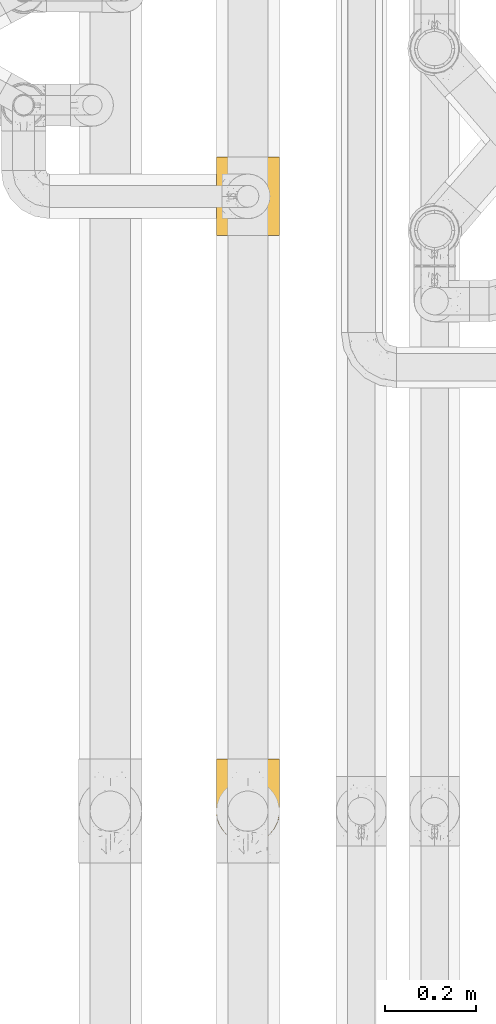
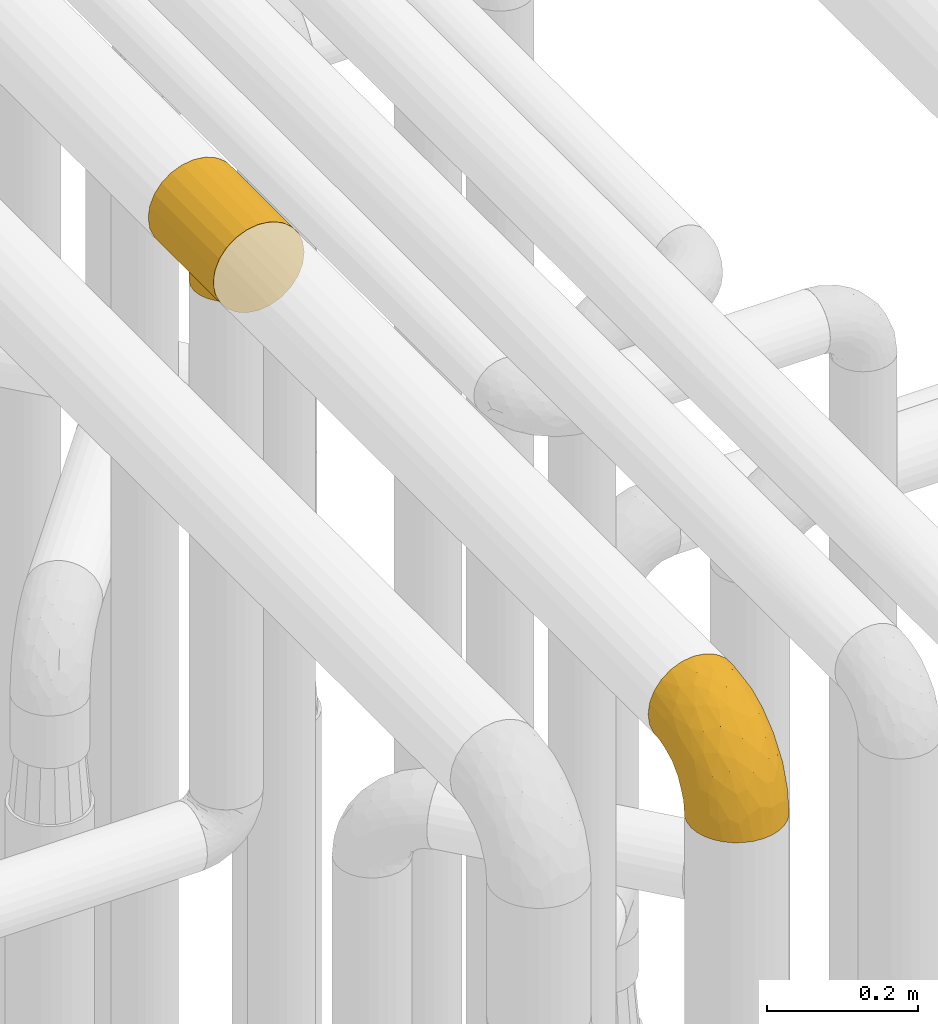
# One storey, part 191 of 827: 2 coverings.
"""IFC2X3 building model written with IfcOpenShell, lengths in millimetres."""

from ifc_helpers import new_model, entity, si_unit, converted_unit, derived_unit, direction, frame, origin, place, context, subcontext, project, spatial, faceted_brep, element, save


model = new_model("IFC2X3")

# Units and contexts
model_context = context("Model", 3, precision=0.01, world=origin(), true_north=direction((6.12303176911189e-17, 1.0)))
body_context = subcontext(model_context, "Body", "Model", "MODEL_VIEW")
ifc_project = project(units=[si_unit("LENGTHUNIT", "METRE", prefix="MILLI"), si_unit("AREAUNIT", "SQUARE_METRE"), si_unit("VOLUMEUNIT", "CUBIC_METRE"), converted_unit("PLANEANGLEUNIT", "DEGREE", entity("IfcRatioMeasure", 0.0174532925199433), si_unit("PLANEANGLEUNIT", "RADIAN"), dimensions=[0, 0, 0, 0, 0, 0, 0]), si_unit("MASSUNIT", "GRAM", prefix="KILO"), derived_unit("MASSDENSITYUNIT", [(si_unit("MASSUNIT", "GRAM", prefix="KILO"), 1), (si_unit("LENGTHUNIT", "METRE"), -3)]), derived_unit("MOMENTOFINERTIAUNIT", [(si_unit("LENGTHUNIT", "METRE"), 4)]), si_unit("TIMEUNIT", "SECOND"), si_unit("FREQUENCYUNIT", "HERTZ"), si_unit("THERMODYNAMICTEMPERATUREUNIT", "DEGREE_CELSIUS"), derived_unit("THERMALTRANSMITTANCEUNIT", [(si_unit("MASSUNIT", "GRAM", prefix="KILO"), 1), (si_unit("THERMODYNAMICTEMPERATUREUNIT", "KELVIN"), -1), (si_unit("TIMEUNIT", "SECOND"), -3)]), derived_unit("VOLUMETRICFLOWRATEUNIT", [(si_unit("LENGTHUNIT", "METRE"), 3), (si_unit("TIMEUNIT", "SECOND"), -1)]), derived_unit("MASSFLOWRATEUNIT", [(si_unit("MASSUNIT", "GRAM", prefix="KILO"), 1), (si_unit("TIMEUNIT", "SECOND"), -1)]), derived_unit("ROTATIONALFREQUENCYUNIT", [(si_unit("TIMEUNIT", "SECOND"), -1)]), si_unit("ELECTRICCURRENTUNIT", "AMPERE"), si_unit("ELECTRICVOLTAGEUNIT", "VOLT"), si_unit("POWERUNIT", "WATT"), si_unit("FORCEUNIT", "NEWTON", prefix="KILO"), si_unit("ILLUMINANCEUNIT", "LUX"), si_unit("LUMINOUSFLUXUNIT", "LUMEN"), si_unit("LUMINOUSINTENSITYUNIT", "CANDELA"), derived_unit("USERDEFINED", [(si_unit("MASSUNIT", "GRAM", prefix="KILO"), -1), (si_unit("LENGTHUNIT", "METRE"), -2), (si_unit("TIMEUNIT", "SECOND"), 3), (si_unit("LUMINOUSFLUXUNIT", "LUMEN"), 1)]), derived_unit("LINEARVELOCITYUNIT", [(si_unit("LENGTHUNIT", "METRE"), 1), (si_unit("TIMEUNIT", "SECOND"), -1)]), si_unit("PRESSUREUNIT", "PASCAL"), derived_unit("USERDEFINED", [(si_unit("LENGTHUNIT", "METRE"), -2), (si_unit("MASSUNIT", "GRAM", prefix="KILO"), 1), (si_unit("TIMEUNIT", "SECOND"), -2)]), derived_unit("LINEARFORCEUNIT", [(si_unit("MASSUNIT", "GRAM", prefix="KILO"), 1), (si_unit("LENGTHUNIT", "METRE"), 1), (si_unit("TIMEUNIT", "SECOND"), -2), (si_unit("LENGTHUNIT", "METRE"), -1)]), derived_unit("PLANARFORCEUNIT", [(si_unit("MASSUNIT", "GRAM", prefix="KILO"), 1), (si_unit("LENGTHUNIT", "METRE"), 1), (si_unit("TIMEUNIT", "SECOND"), -2), (si_unit("LENGTHUNIT", "METRE"), -2)])], contexts=[model_context])

# Site, building, storey
site_placement = place(None, origin())
site = spatial("IfcSite", under=ifc_project, at=site_placement, CompositionType="ELEMENT")
building_placement = place(site_placement, origin())
building = spatial("IfcBuilding", under=site, at=building_placement, CompositionType="ELEMENT")
storey_placement = place(building_placement, frame((0.0, 0.0, 28200.0)))
storey = spatial("IfcBuildingStorey", under=building, at=storey_placement, Name="08", CompositionType="ELEMENT", Elevation=28200.0)

# Coverings
covering_1_placement = place(storey_placement, frame((36148.99, 10070.2, 3477.0)))
element("IfcCovering", 1, at=covering_1_placement, inside=storey, Name=":ADSK_", ObjectType=":ADSK_", PredefinedType="INSULATION", context=body_context, shape_type="Brep", body=[
    faceted_brep([(3.96, 172.0, 90.97), (10.9, 172.0, 107.72), (21.94, 172.0, 122.11), (36.32, 172.0, 133.15), (53.07, 172.0, 140.08), (71.05, 172.0, 142.45), (89.02, 172.0, 140.08), (105.77, 172.0, 133.15), (120.15, 172.0, 122.11), (131.19, 172.0, 107.72), (138.13, 172.0, 90.97), (140.5, 172.0, 73.0), (138.13, 172.0, 55.03), (131.19, 172.0, 38.27), (120.15, 172.0, 23.89), (105.77, 172.0, 12.85), (97.4, 172.0, 9.39), (89.02, 172.0, 5.92), (80.03, 172.0, 4.73), (71.05, 172.0, 3.55), (62.06, 172.0, 4.73), (53.07, 172.0, 5.92), (44.7, 172.0, 9.39), (36.32, 172.0, 12.85), (21.94, 172.0, 23.89), (10.9, 172.0, 38.27), (3.96, 172.0, 55.03), (1.6, 172.0, 73.0), (120.15, 0.0, 122.11), (105.77, 0.0, 133.15), (89.02, 0.0, 140.08), (71.05, 0.0, 142.45), (53.07, 0.0, 140.08), (36.32, 0.0, 133.15), (21.94, 0.0, 122.11), (10.9, 0.0, 107.73), (3.96, 0.0, 90.97), (1.6, 0.0, 73.0), (3.96, 0.0, 55.03), (10.9, 0.0, 38.28), (21.94, 0.0, 23.89), (36.32, 0.0, 12.85), (44.7, 0.0, 9.39), (53.07, 0.0, 5.92), (62.06, 0.0, 4.73), (71.05, 0.0, 3.55), (80.03, 0.0, 4.73), (89.02, 0.0, 5.92), (97.4, 0.0, 9.39), (105.77, 0.0, 12.85), (120.15, 0.0, 23.89), (131.19, 0.0, 38.28), (138.13, 0.0, 55.03), (140.5, 0.0, 73.0), (138.13, 0.0, 90.97), (131.19, 0.0, 107.73), (109.48, 55.36, 15.15), (115.18, 64.37, 19.38), (92.88, 130.03, 7.07), (118.88, 74.72, 22.65), (82.39, 38.18, 4.48), (120.2, 86.0, 23.93), (118.88, 97.28, 22.65), (82.39, 133.82, 4.48), (76.72, 134.49, 4.02), (71.05, 135.15, 3.55), (109.48, 116.64, 15.15), (115.18, 107.63, 19.38), (102.0, 47.82, 10.83), (92.88, 41.97, 7.07), (71.05, 36.85, 3.55), (76.72, 37.51, 4.02), (87.64, 40.07, 5.78), (102.0, 124.18, 10.83), (87.64, 131.93, 5.78), (59.7, 38.18, 4.48), (40.09, 47.82, 10.83), (49.21, 41.97, 7.07), (54.46, 40.07, 5.78), (65.38, 134.49, 4.02), (59.7, 133.82, 4.48), (40.09, 124.18, 10.83), (49.21, 130.03, 7.07), (32.61, 116.64, 15.15), (54.46, 131.93, 5.78), (32.61, 55.36, 15.15), (26.91, 64.37, 19.38), (23.21, 74.72, 22.65), (65.38, 37.51, 4.02), (21.9, 86.0, 23.93), (26.91, 107.63, 19.38), (23.21, 97.28, 22.65), (105.8, 51.25, 0.0), (95.62, 43.43, 0.0), (89.69, 40.98, 0.0), (83.77, 38.52, 0.0), (77.41, 37.69, 0.0), (71.05, 36.85, 0.0), (64.68, 37.69, 0.0), (58.32, 38.52, 0.0), (52.4, 40.98, 0.0), (46.47, 43.43, 0.0), (36.29, 51.25, 0.0), (28.48, 61.42, 0.0), (23.57, 73.28, 0.0), (21.9, 86.0, 0.0), (23.57, 98.72, 0.0), (28.48, 110.57, 0.0), (36.29, 120.75, 0.0), (46.47, 128.57, 0.0), (52.4, 131.02, 0.0), (58.32, 133.48, 0.0), (64.68, 134.31, 0.0), (71.05, 135.15, 0.0), (77.41, 134.31, 0.0), (83.77, 133.48, 0.0), (89.69, 131.02, 0.0), (95.62, 128.57, 0.0), (105.8, 120.75, 0.0), (113.61, 110.57, 0.0), (118.52, 98.72, 0.0), (120.2, 86.0, 0.0), (118.52, 73.28, 0.0), (113.61, 61.42, 0.0)], [[[0, 1, 2, 3, 4, 5, 6, 7, 8, 9, 10, 11, 12, 13, 14, 15, 16, 17, 18, 19, 20, 21, 22, 23, 24, 25, 26, 27]], [[28, 29, 30, 31, 32, 33, 34, 35, 36, 37, 38, 39, 40, 41, 42, 43, 44, 45, 46, 47, 48, 49, 50, 51, 52, 53, 54, 55]], [[29, 28, 8, 7]], [[5, 31, 30, 6]], [[7, 6, 30, 29]], [[9, 55, 54, 10]], [[10, 54, 53, 11]], [[8, 28, 55, 9]], [[52, 12, 11, 53]], [[51, 13, 12, 52]], [[50, 56, 57]], [[56, 50, 49]], [[58, 17, 16]], [[57, 59, 50]], [[60, 47, 46]], [[51, 50, 61]], [[50, 59, 61]], [[61, 62, 14]], [[18, 63, 64, 65]], [[66, 14, 67]], [[67, 14, 62]], [[68, 48, 69]], [[61, 14, 13]], [[61, 13, 51]], [[48, 68, 49]], [[69, 48, 47]], [[45, 70, 46]], [[65, 19, 18]], [[46, 70, 71, 60]], [[47, 60, 72, 69]], [[66, 73, 15]], [[73, 16, 15]], [[16, 73, 58]], [[66, 15, 14]], [[18, 17, 63]], [[17, 58, 74, 63]], [[68, 56, 49]], [[45, 44, 70]], [[65, 20, 19]], [[75, 44, 43]], [[41, 76, 42]], [[77, 42, 76]], [[43, 77, 78, 75]], [[20, 65, 79, 80]], [[81, 23, 22]], [[22, 21, 82]], [[23, 81, 83]], [[21, 80, 84, 82]], [[85, 76, 41]], [[86, 85, 40]], [[87, 86, 40]], [[44, 75, 88, 70]], [[39, 38, 26, 25]], [[89, 40, 39]], [[87, 40, 89]], [[85, 41, 40]], [[26, 38, 37, 27]], [[90, 91, 24]], [[80, 21, 20]], [[83, 24, 23]], [[24, 83, 90]], [[91, 89, 24]], [[77, 43, 42]], [[89, 25, 24]], [[89, 39, 25]], [[81, 22, 82]], [[0, 36, 35, 1]], [[1, 35, 34, 2]], [[37, 36, 0, 27]], [[3, 33, 32, 4]], [[4, 32, 31, 5]], [[2, 34, 33, 3]], [[92, 93, 94, 95, 96, 97, 98, 99, 100, 101, 102, 103, 104, 105, 106, 107, 108, 109, 110, 111, 112, 113, 114, 115, 116, 117, 118, 119, 120, 121, 122, 123]], [[60, 96, 95]], [[69, 94, 93]], [[97, 71, 70]], [[97, 96, 71]], [[95, 72, 60]], [[68, 69, 93]], [[94, 72, 95]], [[96, 60, 71]], [[93, 92, 68]], [[56, 92, 123]], [[122, 121, 59]], [[57, 123, 122]], [[94, 69, 72]], [[56, 123, 57]], [[59, 57, 122]], [[61, 59, 121]], [[92, 56, 68]], [[62, 121, 120]], [[67, 120, 119]], [[61, 121, 62]], [[113, 64, 114]], [[62, 120, 67]], [[119, 66, 67]], [[119, 118, 66]], [[73, 118, 117]], [[63, 74, 115]], [[64, 113, 65]], [[63, 115, 114]], [[58, 73, 117]], [[58, 117, 116]], [[63, 114, 64]], [[116, 74, 58]], [[115, 74, 116]], [[118, 73, 66]], [[80, 112, 111]], [[82, 110, 109]], [[113, 79, 65]], [[113, 112, 79]], [[111, 84, 80]], [[81, 82, 109]], [[110, 84, 111]], [[112, 80, 79]], [[109, 108, 81]], [[83, 108, 107]], [[107, 106, 90]], [[105, 91, 106]], [[110, 82, 84]], [[83, 107, 90]], [[91, 90, 106]], [[89, 91, 105]], [[108, 83, 81]], [[87, 105, 104]], [[86, 104, 103]], [[89, 105, 87]], [[97, 88, 98]], [[87, 104, 86]], [[103, 85, 86]], [[103, 102, 85]], [[76, 102, 101]], [[75, 78, 99]], [[88, 97, 70]], [[75, 99, 98]], [[77, 76, 101]], [[77, 101, 100]], [[75, 98, 88]], [[100, 78, 77]], [[99, 78, 100]], [[102, 76, 85]]]),
])
covering_2_placement = place(storey_placement, frame((36148.99, 8736.34, 3434.41)))
element("IfcCovering", 2, at=covering_2_placement, inside=storey, Name=":ADSK_", ObjectType=":ADSK_", PredefinedType="INSULATION", context=body_context, shape_type="Brep", body=[
    faceted_brep([(135.21, 44.46, 1.6), (128.79, 32.45, 1.6), (120.15, 21.93, 1.6), (109.62, 13.29, 1.6), (97.62, 6.88, 1.6), (84.59, 2.93, 1.6), (71.05, 1.6, 1.6), (57.49, 2.93, 1.6), (44.46, 6.88, 1.6), (32.45, 13.3, 1.6), (21.93, 21.94, 1.6), (13.29, 32.47, 1.6), (6.88, 44.48, 1.6), (2.93, 57.5, 1.6), (1.6, 71.05, 1.6), (2.93, 84.6, 1.6), (6.88, 97.63, 1.6), (13.3, 109.64, 1.6), (21.94, 120.16, 1.6), (32.47, 128.8, 1.6), (44.48, 135.21, 1.6), (57.5, 139.16, 1.6), (71.05, 140.5, 1.6), (84.6, 139.16, 1.6), (97.63, 135.21, 1.6), (109.64, 128.79, 1.6), (120.16, 120.15, 1.6), (128.8, 109.62, 1.6), (135.21, 97.62, 1.6), (139.16, 84.59, 1.6), (140.5, 71.05, 1.6), (139.16, 57.49, 1.6), (71.05, 185.05, 46.15), (53.07, 185.05, 48.51), (36.32, 185.05, 55.45), (21.94, 185.05, 66.49), (10.9, 185.05, 80.87), (3.96, 185.05, 97.62), (1.6, 185.05, 115.6), (3.96, 185.05, 133.57), (10.9, 185.05, 150.32), (21.94, 185.05, 164.7), (36.32, 185.05, 175.74), (53.07, 185.05, 182.68), (71.05, 185.05, 185.05), (89.02, 185.05, 182.68), (105.77, 185.05, 175.74), (120.15, 185.05, 164.7), (131.19, 185.05, 150.32), (138.13, 185.05, 133.57), (140.5, 185.05, 115.6), (138.13, 185.05, 97.62), (131.19, 185.05, 80.87), (120.15, 185.05, 66.49), (105.77, 185.05, 55.45), (89.02, 185.05, 48.51), (111.34, 152.15, 168.96), (95.49, 141.12, 175.13), (108.88, 114.51, 158.73), (83.53, 153.61, 181.18), (71.05, 137.56, 178.79), (120.93, 33.77, 60.46), (130.29, 39.19, 37.64), (128.27, 46.71, 67.76), (135.06, 113.31, 122.9), (131.57, 135.94, 141.27), (124.15, 104.19, 138.22), (137.57, 147.85, 130.26), (139.32, 123.66, 112.44), (138.91, 65.65, 49.74), (134.46, 59.18, 68.04), (136.33, 50.51, 30.86), (96.1, 109.33, 163.55), (83.39, 118.86, 171.5), (123.38, 140.66, 154.96), (71.05, 7.85, 49.08), (89.54, 8.59, 41.64), (84.87, 19.01, 76.28), (99.87, 22.23, 71.48), (138.43, 92.55, 94.09), (132.12, 79.62, 104.13), (140.5, 92.82, 68.6), (140.5, 118.04, 93.82), (140.5, 133.93, 101.92), (140.5, 149.82, 110.02), (123.02, 27.39, 29.29), (92.69, 75.97, 144.77), (71.05, 93.32, 160.47), (71.05, 55.33, 131.31), (101.72, 13.36, 41.7), (112.9, 19.44, 37.35), (88.97, 41.09, 111.47), (140.5, 73.57, 17.55), (140.5, 76.62, 36.82), (106.45, 56.89, 118.92), (113.19, 85.33, 138.29), (120.7, 49.01, 90.59), (71.05, 26.17, 93.32), (140.5, 105.43, 81.21), (111.14, 34.01, 81.15), (140.5, 169.09, 113.07), (121.95, 71.03, 115.61), (101.12, 37.55, 98.71), (140.5, 84.72, 52.71), (97.4, 141.32, 25.32), (90.16, 154.3, 37.45), (104.91, 150.07, 41.91), (138.08, 167.57, 95.84), (138.8, 150.42, 94.09), (119.76, 164.49, 62.73), (139.57, 83.63, 17.88), (136.9, 96.18, 25.24), (108.42, 131.63, 16.53), (121.48, 122.1, 22.28), (133.72, 166.75, 83.66), (100.44, 175.54, 51.78), (104.18, 162.59, 49.56), (88.14, 168.81, 45.37), (84.22, 144.01, 21.96), (127.73, 165.65, 72.88), (116.71, 131.63, 32.42), (139.04, 98.0, 50.57), (138.49, 110.02, 63.77), (94.11, 137.87, 12.83), (117.07, 152.86, 54.57), (130.06, 124.07, 49.25), (129.3, 110.7, 18.24), (71.05, 144.65, 17.09), (71.05, 146.46, 23.87), (133.58, 109.13, 37.05), (139.33, 134.98, 89.71), (137.97, 124.3, 75.2), (134.38, 150.87, 79.98), (71.05, 154.62, 32.02), (128.49, 152.63, 69.19), (117.4, 140.78, 45.42), (129.51, 140.33, 63.69), (71.05, 162.77, 40.18), (71.05, 169.55, 41.99), (57.88, 144.01, 21.96), (4.01, 167.57, 95.84), (8.37, 166.75, 83.66), (3.39, 149.67, 93.31), (51.93, 154.3, 37.45), (14.36, 165.65, 72.88), (7.71, 150.87, 79.98), (53.95, 168.82, 45.37), (37.91, 162.6, 49.57), (33.68, 131.64, 16.53), (20.62, 122.11, 22.28), (41.65, 175.55, 51.78), (5.19, 96.2, 25.24), (1.6, 76.62, 36.82), (1.6, 84.72, 52.71), (1.6, 169.09, 113.07), (1.6, 149.82, 110.02), (22.33, 164.49, 62.73), (12.05, 124.09, 49.23), (25.4, 131.64, 32.41), (12.59, 140.35, 63.68), (24.7, 140.79, 45.41), (14.0, 152.98, 68.72), (25.03, 152.86, 54.57), (48.0, 137.88, 12.82), (1.6, 73.57, 17.55), (12.8, 110.71, 18.25), (3.05, 98.01, 50.56), (8.52, 109.15, 37.06), (4.12, 124.3, 75.19), (44.71, 141.32, 25.3), (2.52, 83.62, 17.89), (37.86, 146.63, 38.1), (1.6, 118.04, 93.82), (3.09, 134.71, 87.62), (3.6, 110.02, 63.77), (1.6, 92.82, 68.6), (1.6, 105.43, 81.21), (1.6, 133.93, 101.92), (33.22, 114.51, 158.73), (30.75, 152.15, 168.96), (18.71, 140.66, 154.96), (5.75, 50.53, 30.86), (13.81, 46.72, 67.75), (11.79, 39.21, 37.64), (21.15, 33.78, 60.46), (2.77, 123.66, 112.44), (17.94, 104.19, 138.22), (35.65, 56.89, 118.92), (21.38, 49.02, 90.58), (30.94, 34.02, 81.16), (3.66, 92.55, 94.09), (4.52, 147.85, 130.26), (40.95, 37.56, 98.71), (10.52, 135.94, 141.27), (58.59, 153.66, 181.2), (46.6, 141.12, 175.13), (58.69, 121.64, 172.56), (7.63, 59.2, 68.05), (3.18, 65.65, 49.74), (7.03, 113.31, 122.9), (46.85, 107.01, 162.8), (53.12, 41.09, 111.47), (49.4, 75.97, 144.77), (9.97, 79.62, 104.13), (19.06, 27.41, 29.29), (40.05, 11.27, 30.45), (20.14, 71.03, 115.61), (29.18, 19.45, 37.36), (42.21, 22.24, 71.5), (52.54, 8.6, 41.65), (57.21, 19.02, 76.29), (58.27, 94.27, 159.64), (28.9, 85.33, 138.29)], [[[0, 1, 2, 3, 4, 5, 6, 7, 8, 9, 10, 11, 12, 13, 14, 15, 16, 17, 18, 19, 20, 21, 22, 23, 24, 25, 26, 27, 28, 29, 30, 31]], [[32, 33, 34, 35, 36, 37, 38, 39, 40, 41, 42, 43, 44, 45, 46, 47, 48, 49, 50, 51, 52, 53, 54, 55]], [[56, 57, 58]], [[59, 44, 60]], [[46, 45, 57]], [[61, 62, 63]], [[64, 65, 66]], [[67, 64, 68]], [[69, 70, 71]], [[57, 72, 58]], [[62, 1, 0]], [[72, 57, 73]], [[74, 47, 56]], [[47, 46, 56]], [[75, 5, 76]], [[77, 76, 78]], [[48, 74, 65]], [[50, 49, 67]], [[79, 64, 80]], [[69, 81, 79]], [[68, 82, 83, 84]], [[64, 66, 80]], [[85, 62, 61]], [[86, 87, 88]], [[4, 3, 89]], [[47, 74, 48]], [[5, 4, 76]], [[85, 2, 1]], [[89, 3, 90]], [[5, 75, 6]], [[59, 73, 57]], [[45, 59, 57]], [[2, 85, 90]], [[63, 62, 70]], [[91, 86, 88]], [[68, 79, 82]], [[69, 30, 92, 93]], [[94, 86, 91]], [[86, 94, 95]], [[71, 62, 0]], [[76, 89, 78]], [[61, 63, 96]], [[88, 97, 91]], [[79, 81, 98, 82]], [[90, 3, 2]], [[99, 90, 61]], [[71, 0, 31]], [[76, 77, 75]], [[58, 95, 66]], [[79, 70, 69]], [[67, 65, 64]], [[77, 91, 97]], [[61, 96, 99]], [[31, 30, 69]], [[70, 62, 71]], [[67, 84, 100, 50]], [[79, 68, 64]], [[84, 67, 68]], [[65, 49, 48]], [[65, 67, 49]], [[66, 65, 74]], [[58, 66, 74]], [[66, 101, 80]], [[99, 102, 78]], [[95, 101, 66]], [[62, 85, 1]], [[90, 85, 61]], [[80, 101, 96]], [[70, 79, 80]], [[86, 95, 58]], [[94, 101, 95]], [[31, 69, 71]], [[69, 93, 103, 81]], [[57, 56, 46]], [[74, 56, 58]], [[77, 78, 102]], [[75, 77, 97]], [[80, 63, 70]], [[63, 80, 96]], [[101, 94, 96]], [[94, 102, 99]], [[94, 99, 96]], [[90, 99, 78]], [[94, 91, 102]], [[77, 102, 91]], [[4, 89, 76]], [[90, 78, 89]], [[44, 59, 45]], [[73, 59, 60]], [[60, 87, 73]], [[86, 73, 87]], [[73, 86, 72]], [[86, 58, 72]], [[104, 105, 106]], [[100, 84, 107]], [[84, 83, 108]], [[51, 100, 107]], [[54, 53, 109]], [[52, 51, 107]], [[110, 111, 93]], [[25, 24, 112]], [[113, 26, 25]], [[53, 52, 114]], [[54, 115, 55]], [[109, 116, 115]], [[115, 117, 55]], [[118, 105, 104]], [[119, 53, 114]], [[104, 106, 120]], [[121, 122, 81]], [[120, 113, 112]], [[112, 113, 25]], [[123, 112, 24]], [[28, 27, 111]], [[124, 106, 116]], [[113, 120, 125]], [[110, 93, 92]], [[30, 29, 92]], [[121, 81, 103]], [[124, 116, 109]], [[27, 126, 111]], [[51, 50, 100]], [[23, 22, 127]], [[127, 128, 118]], [[110, 92, 29]], [[113, 125, 129]], [[126, 113, 129]], [[26, 126, 27]], [[129, 125, 122]], [[123, 24, 23]], [[130, 131, 132]], [[118, 133, 105]], [[103, 93, 111]], [[127, 118, 23]], [[132, 134, 119]], [[118, 104, 123]], [[32, 55, 117]], [[106, 105, 116]], [[113, 126, 26]], [[111, 126, 129]], [[29, 28, 110]], [[111, 110, 28]], [[118, 123, 23]], [[112, 123, 104]], [[104, 120, 112]], [[120, 135, 125]], [[136, 125, 135]], [[82, 98, 131]], [[136, 135, 124]], [[131, 98, 122]], [[131, 125, 136]], [[98, 81, 122]], [[132, 131, 136]], [[121, 111, 129]], [[125, 131, 122]], [[105, 137, 117]], [[138, 32, 117, 137]], [[111, 121, 103]], [[122, 121, 129]], [[132, 114, 108]], [[114, 52, 107]], [[108, 114, 107]], [[108, 83, 130]], [[114, 132, 119]], [[84, 108, 107]], [[83, 82, 130]], [[131, 130, 82]], [[132, 108, 130]], [[134, 132, 136]], [[53, 119, 109]], [[124, 134, 136]], [[109, 119, 134]], [[109, 115, 54]], [[117, 115, 116]], [[105, 117, 116]], [[124, 109, 134]], [[106, 124, 135]], [[133, 118, 128]], [[133, 137, 105]], [[106, 135, 120]], [[139, 133, 128]], [[140, 141, 142]], [[143, 133, 139]], [[21, 139, 127]], [[141, 144, 145]], [[146, 143, 147]], [[148, 19, 149]], [[150, 34, 33]], [[143, 146, 137]], [[151, 152, 153]], [[36, 140, 37]], [[38, 37, 154]], [[154, 140, 155]], [[144, 35, 156]], [[35, 34, 156]], [[149, 157, 158]], [[157, 159, 160]], [[161, 162, 159]], [[21, 127, 22]], [[128, 127, 139]], [[163, 21, 20]], [[15, 14, 164]], [[140, 154, 37]], [[165, 149, 18]], [[17, 165, 18]], [[160, 158, 157]], [[18, 149, 19]], [[148, 20, 19]], [[151, 153, 166]], [[16, 151, 17]], [[151, 167, 165]], [[159, 168, 145]], [[34, 150, 156]], [[158, 169, 148]], [[164, 152, 170]], [[15, 164, 170]], [[170, 151, 16]], [[147, 143, 171]], [[163, 148, 169]], [[21, 163, 139]], [[162, 156, 147]], [[158, 148, 149]], [[139, 169, 143]], [[171, 143, 169]], [[150, 146, 147]], [[151, 165, 17]], [[149, 165, 167]], [[151, 170, 152]], [[16, 15, 170]], [[148, 163, 20]], [[139, 163, 169]], [[157, 149, 167]], [[158, 160, 171]], [[168, 172, 173]], [[174, 175, 176]], [[176, 168, 174]], [[145, 144, 161]], [[166, 174, 167]], [[172, 168, 176]], [[157, 168, 159]], [[168, 157, 174]], [[167, 174, 157]], [[32, 138, 137, 146]], [[166, 153, 175]], [[174, 166, 175]], [[151, 166, 167]], [[36, 141, 140]], [[177, 142, 173]], [[35, 141, 36]], [[140, 142, 155]], [[142, 141, 145]], [[173, 142, 145]], [[142, 177, 155]], [[168, 173, 145]], [[177, 173, 172]], [[35, 144, 141]], [[161, 144, 156]], [[162, 161, 156]], [[145, 161, 159]], [[33, 32, 146]], [[156, 150, 147]], [[33, 146, 150]], [[171, 162, 147]], [[159, 162, 160]], [[143, 137, 133]], [[158, 171, 169]], [[171, 160, 162]], [[178, 179, 180]], [[12, 181, 13]], [[182, 183, 184]], [[185, 155, 177, 172]], [[180, 186, 178]], [[187, 188, 189]], [[190, 172, 176, 175]], [[191, 38, 154, 155]], [[189, 192, 187]], [[39, 191, 193]], [[44, 43, 194]], [[40, 39, 193]], [[195, 196, 194]], [[179, 195, 42]], [[43, 42, 195]], [[40, 180, 41]], [[183, 182, 197]], [[181, 198, 13]], [[42, 41, 179]], [[185, 191, 155]], [[185, 190, 199]], [[200, 195, 178]], [[201, 88, 202]], [[190, 203, 199]], [[14, 13, 198]], [[181, 12, 183]], [[11, 10, 204]], [[9, 8, 205]], [[203, 206, 186]], [[183, 11, 204]], [[189, 207, 208]], [[204, 207, 184]], [[208, 209, 210]], [[88, 201, 97]], [[8, 209, 205]], [[200, 196, 195]], [[208, 207, 205]], [[7, 75, 209]], [[6, 75, 7]], [[211, 88, 87]], [[87, 60, 196]], [[7, 209, 8]], [[210, 75, 97]], [[9, 207, 10]], [[198, 175, 153, 152]], [[198, 190, 175]], [[212, 178, 186]], [[11, 183, 12]], [[180, 193, 186]], [[187, 201, 202]], [[201, 192, 210]], [[183, 197, 181]], [[198, 181, 197]], [[190, 185, 172]], [[191, 185, 199]], [[191, 199, 193]], [[191, 39, 38]], [[199, 203, 186]], [[40, 193, 180]], [[199, 186, 193]], [[186, 206, 212]], [[212, 202, 178]], [[203, 188, 206]], [[207, 204, 10]], [[183, 204, 184]], [[190, 197, 203]], [[182, 203, 197]], [[206, 187, 212]], [[202, 212, 187]], [[190, 198, 197]], [[198, 152, 164, 14]], [[180, 179, 41]], [[195, 179, 178]], [[75, 210, 209]], [[201, 210, 97]], [[188, 182, 184]], [[182, 188, 203]], [[189, 188, 184]], [[187, 206, 188]], [[207, 189, 184]], [[189, 208, 192]], [[210, 192, 208]], [[201, 187, 192]], [[208, 205, 209]], [[9, 205, 207]], [[178, 202, 200]], [[196, 211, 87]], [[196, 200, 211]], [[194, 196, 60]], [[44, 194, 60]], [[195, 194, 43]], [[200, 202, 211]], [[88, 211, 202]]]),
])

save(model, "model.ifc")
